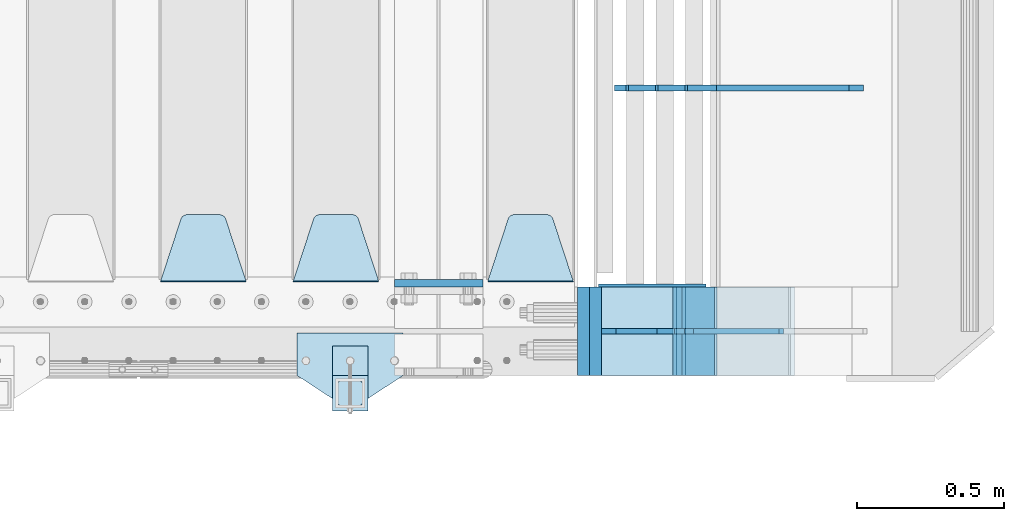
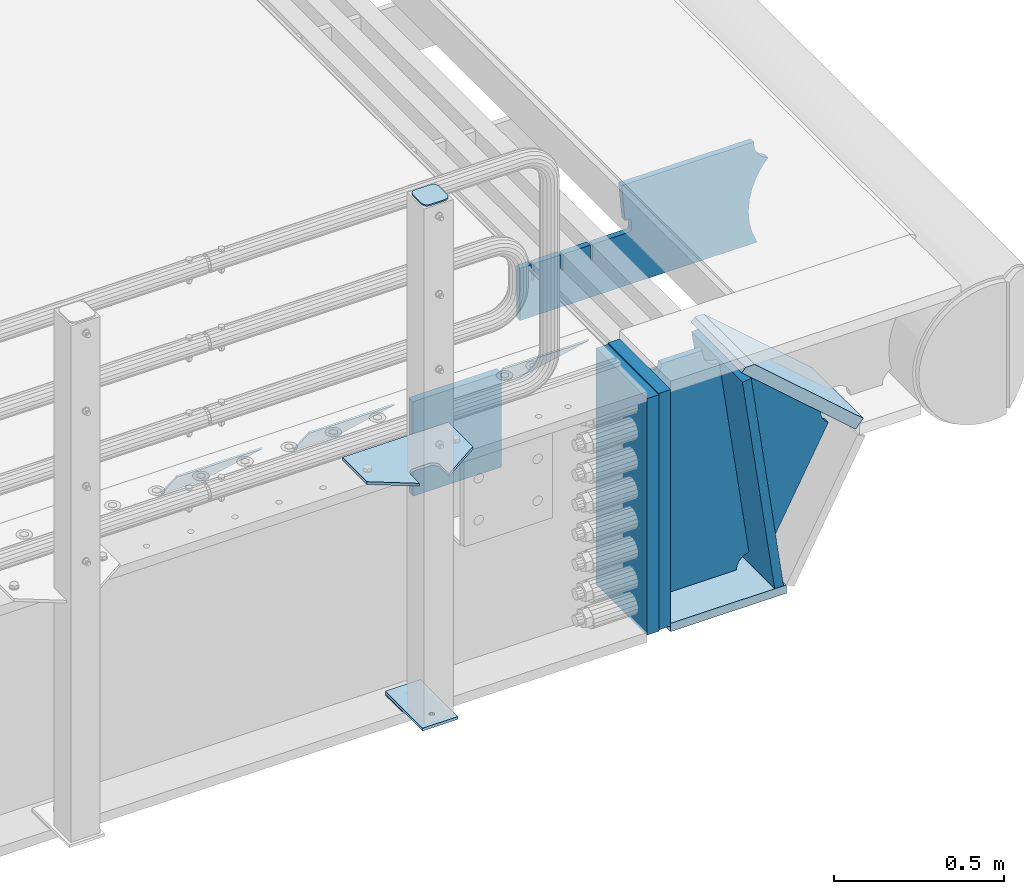
# One storey, part 242 of 270: 17 plates.
"""IFC2X3 building model written with IfcOpenShell, lengths in millimetres."""

import ifcopenshell
import ifcopenshell.guid

model = None  # the IFC model being written
_history = None  # IfcOwnerHistory: only IFC2X3 demands one
_inside = {}  # id of a spatial element -> (the spatial element, [elements in it])
_under = {}  # id of a project, library or spatial element -> (it, [spatial elements below it])
_declared = {}  # id of a project -> (the project, [libraries it declares])
_typed = {}  # id of a type object -> (the type object, [elements of that type])
_made_of = {}  # id of a material, layer set ... -> (it, [elements and type objects made of it])


def new_model(schema):
    """Start an empty IFC model of exactly this schema.

    Asked for "IFC4X3", IfcOpenShell would pick the latest addendum, in which some entities
    have other attributes; the version numbers below select the first issue.
    IFC2X3 requires an IfcOwnerHistory on every rooted entity: one is made here for all.
    """
    global model, _history
    if schema == "IFC4X3":
        model = ifcopenshell.file(schema_version=(4, 3, 0, 0))
    else:
        model = ifcopenshell.file(schema=schema)
    _inside.clear()
    _under.clear()
    _declared.clear()
    _typed.clear()
    _made_of.clear()
    _history = None
    if model.schema == "IFC2X3":
        org = make("IfcOrganization", Name="unknown")
        user = make(
            "IfcPersonAndOrganization",
            ThePerson=make("IfcPerson", FamilyName="unknown"),
            TheOrganization=org,
        )
        app = make(
            "IfcApplication",
            ApplicationDeveloper=org,
            Version="unknown",
            ApplicationFullName="unknown",
            ApplicationIdentifier="unknown",
        )
        _history = make(
            "IfcOwnerHistory",
            OwningUser=user,
            OwningApplication=app,
            ChangeAction="ADDED",
            CreationDate=0,
        )
    return model


def make(cls, **values):
    """One entity of the class cls with the attributes given. An attribute that is None is left unset."""
    return model.create_entity(
        cls, **{name: value for name, value in values.items() if value is not None}
    )


def rooted(cls, **values):
    """An entity with a GlobalId (a new one), such as an element, a storey or a relation."""
    return make(cls, GlobalId=ifcopenshell.guid.new(), OwnerHistory=_history, **values)


def si_unit(unit_type, name, prefix=None):
    """IfcSIUnit, for example si_unit("LENGTHUNIT", "METRE", prefix="MILLI")."""
    return make("IfcSIUnit", UnitType=unit_type, Prefix=prefix, Name=name)


def assignment(units):
    """IfcUnitAssignment: the units of a project."""
    return None if units is None else make("IfcUnitAssignment", Units=units)


def point(xyz):
    """IfcCartesianPoint."""
    return None if xyz is None else make("IfcCartesianPoint", Coordinates=xyz)


def direction(xyz):
    """IfcDirection."""
    return None if xyz is None else make("IfcDirection", DirectionRatios=xyz)


def frame(location, z_axis=None, x_axis=None):
    """IfcAxis2Placement3D, a coordinate frame: its origin and axes. An axis left out is left unset."""
    return make(
        "IfcAxis2Placement3D",
        Location=point(location),
        Axis=direction(z_axis),
        RefDirection=direction(x_axis),
    )


def origin_with_axes():
    """The frame at (0, 0, 0) with the z axis (0, 0, 1) and the x axis (1, 0, 0) written out."""
    return frame((0.0, 0.0, 0.0), z_axis=(0.0, 0.0, 1.0), x_axis=(1.0, 0.0, 0.0))


def place(relative_to, where):
    """IfcLocalPlacement: puts the frame where relative to a parent placement (None: the world)."""
    return make(
        "IfcLocalPlacement", PlacementRelTo=relative_to, RelativePlacement=where
    )


def context(
    kind, dimensions, precision=None, world=None, true_north=None, identifier=None
):
    """IfcGeometricRepresentationContext, for example the 3D "Model" context."""
    return make(
        "IfcGeometricRepresentationContext",
        ContextIdentifier=identifier,
        ContextType=kind,
        CoordinateSpaceDimension=dimensions,
        Precision=precision,
        WorldCoordinateSystem=world,
        TrueNorth=true_north,
    )


def subcontext(parent, identifier, kind, view, scale=None):
    """IfcGeometricRepresentationSubContext, for example "Body" below "Model"."""
    return make(
        "IfcGeometricRepresentationSubContext",
        ContextIdentifier=identifier,
        ContextType=kind,
        ParentContext=parent,
        TargetScale=scale,
        TargetView=view,
    )


def project(units=None, contexts=None):
    """IfcProject with its units and contexts."""
    return rooted(
        "IfcProject",
        Name="project",
        RepresentationContexts=contexts,
        UnitsInContext=assignment(units),
    )


def spatial(cls, under=None, at=None, **own):
    """A site, building, storey or space (cls), placed at a placement, below another one or the project."""
    s = rooted(cls, ObjectPlacement=at, **own)
    if under is not None:
        _under.setdefault(under.id(), (under, []))[1].append(s)
    return s


def faces_of(points, faces, orient=None, outer=None):
    """IfcFace entities. A face is a list of loops; a loop is a list of indices into points, from 0.

    orient and outer hold one flag for each loop. By default every Orientation is true, the
    first loop of a face is its IfcFaceOuterBound and the others are IfcFaceBound.
    """
    made = []
    for i, loops in enumerate(faces):
        bounds = []
        for j, loop in enumerate(loops):
            is_outer = j == 0 if outer is None else outer[i][j]
            bounds.append(
                make(
                    "IfcFaceOuterBound" if is_outer else "IfcFaceBound",
                    Bound=make("IfcPolyLoop", Polygon=[points[k] for k in loop]),
                    Orientation=True if orient is None else orient[i][j],
                )
            )
        made.append(make("IfcFace", Bounds=bounds))
    return made


def faceted_brep(points, faces, orient=None, outer=None, voids=None):
    """IfcFacetedBrep: a solid bounded by flat faces; with voids (closed shells), ...WithVoids."""
    shared = [point(p) for p in points]
    hull = make("IfcClosedShell", CfsFaces=faces_of(shared, faces, orient, outer))
    if voids is None:
        return make("IfcFacetedBrep", Outer=hull)
    return make(
        "IfcFacetedBrepWithVoids",
        Outer=hull,
        Voids=[
            make(cls, CfsFaces=faces_of(shared, fs, o, b)) for cls, fs, o, b in voids
        ],
    )


def shape(context_of_items, identifier, shape_type, items):
    """IfcShapeRepresentation: the items that make up one representation, for example the "Body"."""
    return make(
        "IfcShapeRepresentation",
        ContextOfItems=context_of_items,
        RepresentationIdentifier=identifier,
        RepresentationType=shape_type,
        Items=items,
    )


def material(Name=None, Category=None):
    """IfcMaterial."""
    return make("IfcMaterial", Name=Name, Category=Category)


def made_of(thing, what):
    """Note that an element or type object is made of a material, layer set ...; save() writes the relation."""
    if what is not None:
        _made_of.setdefault(what.id(), (what, []))[1].append(thing)
    return thing


def type_object(cls, material=None, **own):
    """A type object (cls), such as IfcWallType, which elements share."""
    return made_of(rooted(cls, **own), material)


def element(
    cls,
    number,
    at=None,
    inside=None,
    cuts=None,
    type_object=None,
    material=None,
    context=None,
    identifier="Body",
    shape_type=None,
    held_by="IfcProductDefinitionShape",
    body=None,
    shapes=None,
    **own,
):
    """One element of the class cls, such as IfcWall. Its Tag is "e" and its number.

    at: its placement. inside: the storey or other place that contains it. cuts: it is an
    opening in that element (IfcRelVoidsElement). A single representation is given by context,
    identifier, shape_type and body (its items); several are given by shapes. held_by: the class
    of the entity that holds the representations. save() writes the other relations.
    """
    e = rooted(cls, Tag="e%d" % number, ObjectPlacement=at, **own)
    if body is not None:
        shapes = [shape(context, identifier, shape_type, body)]
    if shapes is not None:
        e.Representation = make(held_by, Representations=shapes)
    if inside is not None:
        _inside.setdefault(inside.id(), (inside, []))[1].append(e)
    if cuts is not None:
        rooted(
            "IfcRelVoidsElement", RelatingBuildingElement=cuts, RelatedOpeningElement=e
        )
    if type_object is not None:
        _typed.setdefault(type_object.id(), (type_object, []))[1].append(e)
    return made_of(e, material)


def aggregate(whole, parts):
    """IfcRelAggregates: a whole, such as a stair, and the parts it consists of."""
    return rooted("IfcRelAggregates", RelatingObject=whole, RelatedObjects=parts)


def save(model, path):
    """Write the relations noted so far, then the file.

    IfcRelAggregates (storeys below a building ...), IfcRelContainedInSpatialStructure (elements
    in a storey), IfcRelDefinesByType, IfcRelAssociatesMaterial and IfcRelDeclares: one each for
    every whole, place, type object, material and project.
    """
    for whole, parts in _under.values():
        aggregate(whole, parts)
    for where, things in _inside.values():
        rooted(
            "IfcRelContainedInSpatialStructure",
            RelatedElements=things,
            RelatingStructure=where,
        )
    for kind, things in _typed.values():
        rooted("IfcRelDefinesByType", RelatedObjects=things, RelatingType=kind)
    for what, things in _made_of.values():
        rooted("IfcRelAssociatesMaterial", RelatedObjects=things, RelatingMaterial=what)
    for by, libraries in _declared.values():
        rooted("IfcRelDeclares", RelatingContext=by, RelatedDefinitions=libraries)
    model.write(path)


model = new_model("IFC2X3")

# Units and contexts
model_context = context("Model", 3, precision=1e-05, world=origin_with_axes())
body_context = subcontext(model_context, "Body", "Model", "MODEL_VIEW")
ifc_project = project(units=[si_unit("LENGTHUNIT", "METRE", prefix="MILLI"), si_unit("AREAUNIT", "SQUARE_METRE"), si_unit("VOLUMEUNIT", "CUBIC_METRE"), si_unit("MASSUNIT", "GRAM", prefix="KILO"), si_unit("TIMEUNIT", "SECOND"), si_unit("PLANEANGLEUNIT", "RADIAN"), si_unit("SOLIDANGLEUNIT", "STERADIAN"), si_unit("THERMODYNAMICTEMPERATUREUNIT", "DEGREE_CELSIUS"), si_unit("LUMINOUSINTENSITYUNIT", "LUMEN")], contexts=[model_context])

# Site, building, storey
site_placement = place(None, origin_with_axes())
site = spatial("IfcSite", under=ifc_project, at=site_placement, CompositionType="ELEMENT")
building_placement = place(site_placement, origin_with_axes())
building = spatial("IfcBuilding", under=site, at=building_placement, Name="Standard", CompositionType="ELEMENT")
storey_placement = place(building_placement, origin_with_axes())
storey = spatial("IfcBuildingStorey", under=building, at=storey_placement, Name="Undefined", CompositionType="ELEMENT", Elevation=0.0)

# Plates
ifc_material_1 = material(Name="STEEL/S355N")
plate_type_1 = type_object("IfcPlateType", PredefinedType="NOTDEFINED")
plate_1_placement = place(storey_placement, frame((19768.0, -23837.5, -340.000000000044), z_axis=(0.0, 0.0, 1.0), x_axis=(1.0, 0.0, 0.0)))
element("IfcPlate", 1, at=plate_1_placement, inside=storey, type_object=plate_type_1, material=ifc_material_1, context=body_context, shape_type="Brep", body=[
    faceted_brep([(0.0, -12.5, 0.0), (9.27684595808387e-10, -12.5, 340.0), (9.27684595808387e-10, 12.5, 340.0), (0.0, 12.5, 0.0), (300.0, -12.5, 340.0), (300.0, 12.5, 340.0), (300.0, -12.5, 0.0), (300.0, 12.5, 0.0)], [[[0, 1, 2, 3]], [[1, 4, 5, 2]], [[4, 6, 7, 5]], [[6, 0, 3, 7]], [[5, 7, 3, 2]], [[6, 4, 1, 0]]]),
])
ifc_material_2 = material(Name="STEEL/S355J2")
plate_type_2 = type_object("IfcPlateType", PredefinedType="NOTDEFINED")
plate_2_placement = place(storey_placement, frame((19798.0, -24005.0, 5.00000000004911), z_axis=(0.0, -1.0, 0.0), x_axis=(-1.0, 0.0, 0.0)))
element("IfcPlate", 2, at=plate_2_placement, inside=storey, type_object=plate_type_2, material=ifc_material_2, context=body_context, shape_type="Brep", body=[
    faceted_brep([(0.0, -5.0, 0.0), (2.31396552408114e-06, -5.0, 145.0), (2.31396552408114e-06, 5.0, 145.0), (0.0, 5.0, 0.0), (130.0, -5.0, 230.0), (130.0, 5.0, 230.0), (130.0, -5.0, 180.0), (130.0, 5.0, 180.0), (130.48036798992, -5.0, 175.122741949597), (130.48036798992, 5.0, 175.122741949597), (131.903011687216, -5.0, 170.432914190873), (131.903011687216, 5.0, 170.432914190873), (134.213259692435, -5.0, 166.11074417451), (134.213259692435, 5.0, 166.11074417451), (137.322330470335, -5.0, 162.322330470337), (137.322330470335, 5.0, 162.322330470337), (141.110744174512, -5.0, 159.213259692437), (141.110744174512, 5.0, 159.213259692437), (145.432914190871, -5.0, 156.903011687218), (145.432914190871, 5.0, 156.903011687218), (150.122741949595, -5.0, 155.48036798992), (150.122741949595, 5.0, 155.48036798992), (155.0, -5.0, 155.0), (155.0, 5.0, 155.0), (205.0, -5.0, 155.0), (205.0, 5.0, 155.0), (209.877258050405, -5.0, 155.48036798992), (209.877258050405, 5.0, 155.48036798992), (214.567085809129, -5.0, 156.903011687218), (214.567085809129, 5.0, 156.903011687218), (218.889255825488, -5.0, 159.213259692437), (218.889255825488, 5.0, 159.213259692437), (222.677669529665, -5.0, 162.322330470337), (222.677669529665, 5.0, 162.322330470337), (225.786740307565, -5.0, 166.11074417451), (225.786740307565, 5.0, 166.11074417451), (228.096988312784, -5.0, 170.432914190873), (228.096988312784, 5.0, 170.432914190873), (229.51963201008, -5.0, 175.122741949597), (229.51963201008, 5.0, 175.122741949597), (230.0, -5.0, 180.0), (230.0, 5.0, 180.0), (230.0, -5.0, 230.0), (230.0, 5.0, 230.0), (360.0, -5.0, 145.0), (360.0, 5.0, 145.0), (360.0, -5.0, -7.27595761418343e-12), (360.0, 5.0, -7.27595761418343e-12)], [[[0, 1, 2, 3]], [[1, 4, 5, 2]], [[4, 6, 7, 5]], [[6, 8, 9, 7]], [[8, 10, 11, 9]], [[10, 12, 13, 11]], [[12, 14, 15, 13]], [[14, 16, 17, 15]], [[16, 18, 19, 17]], [[18, 20, 21, 19]], [[20, 22, 23, 21]], [[22, 24, 25, 23]], [[24, 26, 27, 25]], [[26, 28, 29, 27]], [[28, 30, 31, 29]], [[30, 32, 33, 31]], [[32, 34, 35, 33]], [[34, 36, 37, 35]], [[36, 38, 39, 37]], [[38, 40, 41, 39]], [[40, 42, 43, 41]], [[42, 44, 45, 43]], [[44, 46, 47, 45]], [[46, 0, 3, 47]], [[5, 7, 9, 11, 13, 15, 17, 19, 21, 23, 25, 27, 29, 31, 33, 35, 37, 39, 41, 43, 45, 47, 3, 2]], [[46, 44, 42, 40, 38, 36, 34, 32, 30, 28, 26, 24, 22, 20, 18, 16, 14, 12, 10, 8, 6, 4, 1, 0]]]),
])
plate_type_3 = type_object("IfcPlateType", PredefinedType="NOTDEFINED")
plate_3_placement = place(storey_placement, frame((19677.9999999999, -24050.0000000002, -850.000000000002), z_axis=(0.0, -1.0, 0.0), x_axis=(-1.0, 0.0, 0.0)))
element("IfcPlate", 3, at=plate_3_placement, inside=storey, type_object=plate_type_3, material=ifc_material_2, context=body_context, shape_type="Brep", body=[
    faceted_brep([(53.6360389691836, -5.0, 176.363961030471), (53.6360389691836, 5.0, 176.363961030471), (59.9999999998618, 5.0, 178.999999999793), (59.9999999998618, -5.0, 178.999999999793), (66.3639610305399, 5.0, 176.363961030471), (66.3639610305399, -5.0, 176.363961030471), (68.9999999998618, 5.0, 169.999999999793), (68.9999999998618, -5.0, 169.999999999793), (66.3639610305399, 5.0, 163.636038969114), (66.3639610305399, -5.0, 163.636038969114), (59.9999999998618, 5.0, 160.999999999793), (59.9999999998618, -5.0, 160.999999999793), (53.6360389691836, 5.0, 163.636038969114), (53.6360389691836, -5.0, 163.636038969114), (50.9999999998618, 5.0, 169.999999999793), (50.9999999998618, -5.0, 169.999999999793), (120.0, -5.0, 0.0), (120.0, -5.0, 220.0), (0.0, -5.0, 220.0), (0.0, -5.0, 0.0), (0.0, 5.0, 0.0), (120.0, 5.0, 0.0), (120.0, 5.0, 220.0), (0.0, 5.0, 220.0)], [[[0, 1, 2, 3]], [[3, 2, 4, 5]], [[5, 4, 6, 7]], [[7, 6, 8, 9]], [[9, 8, 10, 11]], [[11, 10, 12, 13]], [[13, 12, 14, 15]], [[15, 14, 1, 0]], [[16, 17, 18, 19], [11, 13, 15, 0, 3, 5, 7, 9]], [[16, 19, 20, 21]], [[17, 16, 21, 22]], [[18, 17, 22, 23]], [[19, 18, 23, 20]], [[22, 21, 20, 23], [2, 1, 14, 12, 10, 8, 6, 4]]]),
])
plate_type_4 = type_object("IfcPlateType", PredefinedType="NOTDEFINED")
plate_4_placement = place(storey_placement, frame((19573.9999999999, -24166.0000000002, 1012.50000000001), z_axis=(0.0, -1.0, 0.0), x_axis=(1.0, 0.0, 0.0)))
element("IfcPlate", 4, at=plate_4_placement, inside=storey, type_object=plate_type_4, material=ifc_material_2, context=body_context, shape_type="Brep", body=[
    faceted_brep([(0.0, -2.5, 19.0), (0.0, -2.5, 69.0), (0.0, 2.5, 69.0), (0.0, 2.5, 19.0), (0.476369668544066, -2.5, 73.2278977451697), (0.476369668544066, 2.5, 73.2278977451697), (1.88159150985302, -2.5, 77.2437910432327), (1.88159150985302, 2.5, 77.2437910432327), (4.14520183310742, -2.5, 80.8463062353167), (4.14520183310742, 2.5, 80.8463062353167), (7.15369376468516, -2.5, 83.8547981668926), (7.15369376468516, 2.5, 83.8547981668926), (10.7562089567655, -2.5, 86.1184084901452), (10.7562089567655, 2.5, 86.1184084901452), (14.7721022548285, -2.5, 87.5236303314541), (14.7721022548285, 2.5, 87.5236303314541), (19.0, -2.5, 88.0), (19.0, 2.5, 88.0), (69.0, -2.5, 88.0), (69.0, 2.5, 88.0), (73.2278977451715, -2.5, 87.5236303314541), (73.2278977451715, 2.5, 87.5236303314541), (77.2437910432345, -2.5, 86.1184084901452), (77.2437910432345, 2.5, 86.1184084901452), (80.8463062353148, -2.5, 83.8547981668926), (80.8463062353148, 2.5, 83.8547981668926), (83.8547981668926, -2.5, 80.8463062353167), (83.8547981668926, 2.5, 80.8463062353167), (86.118408490147, -2.5, 77.2437910432345), (86.118408490147, 2.5, 77.2437910432345), (87.5236303314559, -2.5, 73.2278977451697), (87.5236303314559, 2.5, 73.2278977451697), (88.0, -2.5, 69.0), (88.0, 2.5, 69.0), (88.0, -2.5, 19.0), (88.0, 2.5, 19.0), (87.5236303314559, -2.5, 14.7721022548303), (87.5236303314559, 2.5, 14.7721022548303), (86.118408490147, -2.5, 10.7562089567673), (86.118408490147, 2.5, 10.7562089567673), (83.8547981668926, -2.5, 7.15369376468334), (83.8547981668926, 2.5, 7.15369376468334), (80.8463062353148, -2.5, 4.14520183310742), (80.8463062353148, 2.5, 4.14520183310742), (77.2437910432345, -2.5, 1.88159150985484), (77.2437910432345, 2.5, 1.88159150985484), (73.2278977451715, -2.5, 0.476369668545885), (73.2278977451715, 2.5, 0.476369668545885), (69.0, -2.5, 0.0), (69.0, 2.5, 0.0), (19.0, -2.5, 0.0), (19.0, 2.5, 0.0), (14.7721022548285, -2.5, 0.476369668545885), (14.7721022548285, 2.5, 0.476369668545885), (10.7562089567655, -2.5, 1.88159150985484), (10.7562089567655, 2.5, 1.88159150985484), (7.15369376468516, -2.5, 4.14520183310742), (7.15369376468516, 2.5, 4.14520183310742), (4.14520183310742, -2.5, 7.15369376468334), (4.14520183310742, 2.5, 7.15369376468334), (1.88159150985302, -2.5, 10.7562089567673), (1.88159150985302, 2.5, 10.7562089567673), (0.476369668544066, -2.5, 14.7721022548303), (0.476369668544066, 2.5, 14.7721022548303)], [[[0, 1, 2, 3]], [[1, 4, 5, 2]], [[4, 6, 7, 5]], [[6, 8, 9, 7]], [[8, 10, 11, 9]], [[10, 12, 13, 11]], [[12, 14, 15, 13]], [[14, 16, 17, 15]], [[16, 18, 19, 17]], [[18, 20, 21, 19]], [[20, 22, 23, 21]], [[22, 24, 25, 23]], [[24, 26, 27, 25]], [[26, 28, 29, 27]], [[28, 30, 31, 29]], [[30, 32, 33, 31]], [[32, 34, 35, 33]], [[34, 36, 37, 35]], [[36, 38, 39, 37]], [[38, 40, 41, 39]], [[40, 42, 43, 41]], [[42, 44, 45, 43]], [[44, 46, 47, 45]], [[46, 48, 49, 47]], [[48, 50, 51, 49]], [[50, 52, 53, 51]], [[52, 54, 55, 53]], [[54, 56, 57, 55]], [[56, 58, 59, 57]], [[58, 60, 61, 59]], [[60, 62, 63, 61]], [[62, 0, 3, 63]], [[5, 7, 9, 11, 13, 15, 17, 19, 21, 23, 25, 27, 29, 31, 33, 35, 37, 39, 41, 43, 45, 47, 49, 51, 53, 55, 57, 59, 61, 63, 3, 2]], [[62, 60, 58, 56, 54, 52, 50, 48, 46, 44, 42, 40, 38, 36, 34, 32, 30, 28, 26, 24, 22, 20, 18, 16, 14, 12, 10, 8, 6, 4, 1, 0]]]),
])
plate_type_5 = type_object("IfcPlateType", PredefinedType="NOTDEFINED")
plate_5_placement = place(storey_placement, frame((19677.9999999999, -24050.0000000002, -857.500000000002), z_axis=(0.0, -1.0, 0.0), x_axis=(-1.0, 0.0, 0.0)))
element("IfcPlate", 5, at=plate_5_placement, inside=storey, type_object=plate_type_5, material=ifc_material_2, context=body_context, shape_type="Brep", body=[
    faceted_brep([(0.0, -2.5, 0.0), (0.0, -2.5, 100.0), (0.0, 2.5, 100.0), (0.0, 2.5, 0.0), (120.0, -2.5, 100.0), (120.0, 2.5, 100.0), (120.0, -2.5, 0.0), (120.0, 2.5, 0.0)], [[[0, 1, 2, 3]], [[1, 4, 5, 2]], [[4, 6, 7, 5]], [[6, 0, 3, 7]], [[5, 7, 3, 2]], [[6, 4, 1, 0]]]),
])
plate_type_6 = type_object("IfcPlateType", PredefinedType="NOTDEFINED")
plate_6_placement = place(storey_placement, frame((20375.0, -23831.767766953, -1.76776695296758), z_axis=(0.0, 0.707106781186547, -0.707106781186548), x_axis=(-1.0, 0.0, 0.0)))
element("IfcPlate", 6, at=plate_6_placement, inside=storey, type_object=plate_type_6, material=ifc_material_1, context=body_context, shape_type="Brep", body=[
    faceted_brep([(0.0, -2.5, 0.0), (69.345504679477, -2.5, 300.171731424831), (69.345504679477, 2.5, 300.171731424831), (0.0, 2.5, 0.0), (70.9274061199576, -2.5, 304.8974424154), (70.9274061199576, 2.5, 304.8974424154), (73.3818627772307, -2.49999999999818, 309.234538108527), (73.3818627772307, 2.50000000000182, 309.234538108527), (76.6187032999551, -2.5, 313.023683126103), (76.6187032999551, 2.5, 313.023683126103), (80.5190132704993, -2.5, 316.125672595372), (80.5190132704993, 2.50000000000182, 316.125672595372), (84.9395038596849, -2.49999999999818, 318.426546230476), (84.9395038596849, 2.5, 318.426546230476), (89.7177759439219, -2.49999999999818, 319.841774983275), (89.7177759439219, 2.50000000000182, 319.841774983275), (94.678286292652, -2.5, 320.319366455078), (94.678286292652, 2.5, 320.319366455078), (195.321713707348, -2.5, 320.319366455078), (195.321713707348, 2.5, 320.319366455078), (200.282224056078, -2.49999999999818, 319.841774983275), (200.282224056078, 2.50000000000182, 319.841774983275), (205.060496140315, -2.5, 318.426546230476), (205.060496140315, 2.5, 318.426546230476), (209.480986729501, -2.5, 316.12567259537), (209.480986729501, 2.50000000000182, 316.12567259537), (213.381296700045, -2.5, 313.023683126103), (213.381296700045, 2.5, 313.023683126103), (216.618137222769, -2.49999999999818, 309.234538108525), (216.618137222769, 2.50000000000182, 309.234538108527), (219.072593880042, -2.49999999999818, 304.897442415398), (219.072593880042, 2.50000000000182, 304.897442415397), (220.654495320523, -2.5, 300.171731424831), (220.654495320523, 2.5, 300.171731424831), (290.0, -2.49999999999818, 0.0), (290.0, 2.5, 0.0)], [[[0, 1, 2, 3]], [[1, 4, 5, 2]], [[4, 6, 7, 5]], [[6, 8, 9, 7]], [[8, 10, 11, 9]], [[10, 12, 13, 11]], [[12, 14, 15, 13]], [[14, 16, 17, 15]], [[16, 18, 19, 17]], [[18, 20, 21, 19]], [[20, 22, 23, 21]], [[22, 24, 25, 23]], [[24, 26, 27, 25]], [[26, 28, 29, 27]], [[28, 30, 31, 29]], [[30, 32, 33, 31]], [[32, 34, 35, 33]], [[34, 0, 3, 35]], [[5, 7, 9, 11, 13, 15, 17, 19, 21, 23, 25, 27, 29, 31, 33, 35, 3, 2]], [[34, 32, 30, 28, 26, 24, 22, 20, 18, 16, 14, 12, 10, 8, 6, 4, 1, 0]]]),
])
plate_7_placement = place(storey_placement, frame((19715.0, -23831.767766953, -1.76776695296758), z_axis=(0.0, 0.707106781186547, -0.707106781186548), x_axis=(-1.0, 0.0, 0.0)))
element("IfcPlate", 7, at=plate_7_placement, inside=storey, type_object=plate_type_6, material=ifc_material_1, context=body_context, shape_type="Brep", body=[
    faceted_brep([(0.0, -2.5, 0.0), (69.345504679477, -2.5, 300.171731424831), (69.345504679477, 2.5, 300.171731424831), (0.0, 2.5, 0.0), (70.9274061199576, -2.5, 304.8974424154), (70.9274061199576, 2.5, 304.8974424154), (73.3818627772307, -2.49999999999818, 309.234538108527), (73.3818627772307, 2.50000000000182, 309.234538108527), (76.6187032999551, -2.5, 313.023683126103), (76.6187032999551, 2.5, 313.023683126103), (80.5190132704993, -2.5, 316.125672595372), (80.5190132704993, 2.50000000000182, 316.125672595372), (84.9395038596849, -2.49999999999818, 318.426546230476), (84.9395038596849, 2.5, 318.426546230476), (89.7177759439219, -2.49999999999818, 319.841774983275), (89.7177759439219, 2.50000000000182, 319.841774983275), (94.678286292652, -2.5, 320.319366455078), (94.678286292652, 2.5, 320.319366455078), (195.321713707348, -2.5, 320.319366455078), (195.321713707348, 2.5, 320.319366455078), (200.282224056078, -2.49999999999818, 319.841774983275), (200.282224056078, 2.50000000000182, 319.841774983275), (205.060496140315, -2.5, 318.426546230476), (205.060496140315, 2.5, 318.426546230476), (209.480986729501, -2.5, 316.12567259537), (209.480986729501, 2.50000000000182, 316.12567259537), (213.381296700045, -2.5, 313.023683126103), (213.381296700045, 2.5, 313.023683126103), (216.618137222769, -2.49999999999818, 309.234538108525), (216.618137222769, 2.50000000000182, 309.234538108527), (219.072593880042, -2.49999999999818, 304.897442415398), (219.072593880042, 2.50000000000182, 304.897442415397), (220.654495320523, -2.5, 300.171731424831), (220.654495320523, 2.5, 300.171731424831), (290.0, -2.49999999999818, 0.0), (290.0, 2.5, 0.0)], [[[0, 1, 2, 3]], [[1, 4, 5, 2]], [[4, 6, 7, 5]], [[6, 8, 9, 7]], [[8, 10, 11, 9]], [[10, 12, 13, 11]], [[12, 14, 15, 13]], [[14, 16, 17, 15]], [[16, 18, 19, 17]], [[18, 20, 21, 19]], [[20, 22, 23, 21]], [[22, 24, 25, 23]], [[24, 26, 27, 25]], [[26, 28, 29, 27]], [[28, 30, 31, 29]], [[30, 32, 33, 31]], [[32, 34, 35, 33]], [[34, 0, 3, 35]], [[5, 7, 9, 11, 13, 15, 17, 19, 21, 23, 25, 27, 29, 31, 33, 35, 3, 2]], [[34, 32, 30, 28, 26, 24, 22, 20, 18, 16, 14, 12, 10, 8, 6, 4, 1, 0]]]),
])
plate_8_placement = place(storey_placement, frame((19265.0, -23831.767766953, -1.76776695296758), z_axis=(0.0, 0.707106781186547, -0.707106781186548), x_axis=(-1.0, 0.0, 0.0)))
element("IfcPlate", 8, at=plate_8_placement, inside=storey, type_object=plate_type_6, material=ifc_material_1, context=body_context, shape_type="Brep", body=[
    faceted_brep([(0.0, -2.5, 0.0), (69.345504679477, -2.5, 300.171731424831), (69.345504679477, 2.5, 300.171731424831), (0.0, 2.5, 0.0), (70.9274061199576, -2.5, 304.8974424154), (70.9274061199576, 2.5, 304.8974424154), (73.3818627772307, -2.49999999999818, 309.234538108527), (73.3818627772307, 2.50000000000182, 309.234538108527), (76.6187032999551, -2.5, 313.023683126103), (76.6187032999551, 2.5, 313.023683126103), (80.5190132704993, -2.5, 316.125672595372), (80.5190132704993, 2.50000000000182, 316.125672595372), (84.9395038596849, -2.49999999999818, 318.426546230476), (84.9395038596849, 2.5, 318.426546230476), (89.7177759439219, -2.49999999999818, 319.841774983275), (89.7177759439219, 2.50000000000182, 319.841774983275), (94.678286292652, -2.5, 320.319366455078), (94.678286292652, 2.5, 320.319366455078), (195.321713707348, -2.5, 320.319366455078), (195.321713707348, 2.5, 320.319366455078), (200.282224056078, -2.49999999999818, 319.841774983275), (200.282224056078, 2.50000000000182, 319.841774983275), (205.060496140315, -2.5, 318.426546230476), (205.060496140315, 2.5, 318.426546230476), (209.480986729501, -2.5, 316.12567259537), (209.480986729501, 2.50000000000182, 316.12567259537), (213.381296700045, -2.5, 313.023683126103), (213.381296700045, 2.5, 313.023683126103), (216.618137222769, -2.49999999999818, 309.234538108525), (216.618137222769, 2.50000000000182, 309.234538108527), (219.072593880042, -2.49999999999818, 304.897442415398), (219.072593880042, 2.50000000000182, 304.897442415397), (220.654495320523, -2.5, 300.171731424831), (220.654495320523, 2.5, 300.171731424831), (290.0, -2.49999999999818, 0.0), (290.0, 2.5, 0.0)], [[[0, 1, 2, 3]], [[1, 4, 5, 2]], [[4, 6, 7, 5]], [[6, 8, 9, 7]], [[8, 10, 11, 9]], [[10, 12, 13, 11]], [[12, 14, 15, 13]], [[14, 16, 17, 15]], [[16, 18, 19, 17]], [[18, 20, 21, 19]], [[20, 22, 23, 21]], [[22, 24, 25, 23]], [[24, 26, 27, 25]], [[26, 28, 29, 27]], [[28, 30, 31, 29]], [[30, 32, 33, 31]], [[32, 34, 35, 33]], [[34, 0, 3, 35]], [[5, 7, 9, 11, 13, 15, 17, 19, 21, 23, 25, 27, 29, 31, 33, 35, 3, 2]], [[34, 32, 30, 28, 26, 24, 22, 20, 18, 16, 14, 12, 10, 8, 6, 4, 1, 0]]]),
])
plate_type_7 = type_object("IfcPlateType", PredefinedType="NOTDEFINED")
plate_9_placement = place(storey_placement, frame((21111.9988298898, -23850.0000000008, -367.999999998825), z_axis=(-0.752989422949573, 0.0, 0.658032619955933), x_axis=(0.0, -1.0, 0.0)))
element("IfcPlate", 9, at=plate_9_placement, inside=storey, type_object=plate_type_7, material=ifc_material_1, context=body_context, shape_type="Brep", body=[
    faceted_brep([(-8.11269273981452e-10, 19.9999999999982, 490.766265601622), (0.0, -0.303811250943909, 514.0), (300.0, -0.303811250943909, 514.0), (300.0, 19.9999999999982, 490.766265601622), (300.0, -20.0, -1.81898940354586e-12), (300.0, -20.0000000000018, 514.000000000002), (0.0, -20.0000000000018, 514.000000000002), (0.0, -20.0, 0.0), (0.0, 20.0, 0.0), (300.0, 20.0, -1.81898940354586e-12)], [[[0, 1, 2, 3]], [[4, 5, 6, 7]], [[4, 7, 8, 9]], [[9, 8, 0, 3]], [[5, 4, 9, 3, 2]], [[6, 5, 2, 1]], [[8, 7, 6, 1, 0]]]),
])
ifc_material_3 = material()
for number, where, z_axis, x_axis in (
    (10, (20449.9988298907, -23850.0, -869.999999999526), (0.0, 0.0, 1.0), (0.0, -1.0, 0.0)),
    (11, (20410.0, -23850.0, -875.0), (0.0, 0.0, 1.0), (0.0, -1.0, 0.0)),
):
    element("IfcPlate", number, at=place(storey_placement, frame(where, z_axis=z_axis, x_axis=x_axis)), inside=storey, type_object=plate_type_7, material=ifc_material_3, context=body_context, shape_type="Brep", body=[
        faceted_brep([(0.0, -20.0, 0.0), (0.0, -20.0, 850.0), (0.0, 20.0, 850.0), (0.0, 20.0, 0.0), (300.0, -20.0, 850.0), (300.0, 20.0, 850.0), (300.0, -20.0, -1.81898940354586e-12), (300.0, 20.0, -1.81898940354586e-12)], [[[0, 1, 2, 3]], [[1, 4, 5, 2]], [[4, 6, 7, 5]], [[6, 0, 3, 7]], [[5, 7, 3, 2]], [[6, 4, 1, 0]]]),
    ])
plate_type_8 = type_object("IfcPlateType", PredefinedType="NOTDEFINED")
plate_10_placement = place(storey_placement, frame((20708.9988298891, -24000.0, -30.0000000027761), z_axis=(0.0, 0.0, -1.0), x_axis=(-1.0, 0.0, 0.0)))
element("IfcPlate", 12, at=plate_10_placement, inside=storey, type_object=plate_type_8, material=ifc_material_1, context=body_context, shape_type="Brep", body=[
    faceted_brep([(-9.00602409638668, -10.0, 65.0), (-108.137843376921, -10.0, 780.473130459514), (-108.137843376921, 10.0, 780.473130459514), (-9.00602409638668, 10.0, 65.0), (-94.4157884488377, -10.0, 784.433672138112), (-94.4157884488377, 10.0, 784.433672138112), (-82.3732461236723, -10.0, 792.112074067144), (-82.3732461236723, 10.0, 792.112074067144), (-72.9927947992364, -10.0, 802.881837982249), (-72.9927947992364, 10.0, 802.881837982249), (-67.0398068183713, -10.0, 815.864234368775), (-67.0398068183713, 10.0, 815.864234368775), (-65.0, -10.0, 830.0), (-65.0, 10.0, 830.0), (189.0, -10.0, 830.0), (189.0, 10.0, 830.0), (191.447174185243, -10.0, 814.549150281253), (191.447174185243, 10.0, 814.549150281253), (198.549150281251, -10.0, 800.610737385376), (198.549150281251, 10.0, 800.610737385376), (209.610737385377, -10.0, 789.549150281253), (209.610737385377, 10.0, 789.549150281253), (223.549150281251, -10.0, 782.447174185242), (223.549150281251, 10.0, 782.447174185242), (239.0, -10.0, 780.0), (239.0, 10.0, 780.0), (239.0, -10.0, 50.0), (239.0, 10.0, 50.0), (223.549150281251, -10.0, 47.5528258147577), (223.549150281251, 10.0, 47.5528258147577), (209.610737385377, -10.0, 40.4508497187474), (209.610737385377, 10.0, 40.4508497187474), (198.549150281251, -10.0, 29.3892626146237), (198.549150281251, 10.0, 29.3892626146237), (191.447174185243, -10.0, 15.4508497187474), (191.447174185243, 10.0, 15.4508497187474), (189.0, -10.0, 0.0), (189.0, 10.0, 0.0), (50.4776502774184, -10.0, 0.0), (50.4776502774184, 10.0, 0.0), (47.3830020671812, -10.0, 22.3352870825933), (47.3830020671812, 10.0, 22.3352870825933), (42.8384615202776, -10.0, 37.3040735979326), (42.8384615202776, 10.0, 37.3040735979326), (33.8907372011709, -10.0, 50.1358952937587), (33.8907372011709, 10.0, 50.1358952937587), (21.4156947086703, -10.0, 59.5746840579253), (21.4156947086703, 10.0, 59.5746840579253), (6.63447812067898, -10.0, 64.6965054822873), (6.63447812067898, 10.0, 64.6965054822873)], [[[0, 1, 2, 3]], [[1, 4, 5, 2]], [[4, 6, 7, 5]], [[6, 8, 9, 7]], [[8, 10, 11, 9]], [[10, 12, 13, 11]], [[12, 14, 15, 13]], [[14, 16, 17, 15]], [[16, 18, 19, 17]], [[18, 20, 21, 19]], [[20, 22, 23, 21]], [[22, 24, 25, 23]], [[24, 26, 27, 25]], [[26, 28, 29, 27]], [[28, 30, 31, 29]], [[30, 32, 33, 31]], [[32, 34, 35, 33]], [[34, 36, 37, 35]], [[36, 38, 39, 37]], [[38, 40, 41, 39]], [[40, 42, 43, 41]], [[42, 44, 45, 43]], [[44, 46, 47, 45]], [[46, 48, 49, 47]], [[48, 0, 3, 49]], [[5, 7, 9, 11, 13, 15, 17, 19, 21, 23, 25, 27, 29, 31, 33, 35, 37, 39, 41, 43, 45, 47, 49, 3, 2]], [[48, 46, 44, 42, 40, 38, 36, 34, 32, 30, 28, 26, 24, 22, 20, 18, 16, 14, 12, 10, 8, 6, 4, 1, 0]]]),
])
plate_type_9 = type_object("IfcPlateType", PredefinedType="NOTDEFINED")
plate_11_placement = place(storey_placement, frame((21111.0025685034, -23999.999999999, -393.99668820393), z_axis=(-0.658066357015091, 0.0, -0.752959939017267), x_axis=(-0.752959939017266, 0.0, 0.658066357015093)))
element("IfcPlate", 13, at=plate_11_placement, inside=storey, type_object=plate_type_9, material=ifc_material_1, context=body_context, shape_type="Brep", body=[
    faceted_brep([(-11.3595226159596, -10.0, 48.6925173505915), (-112.015767301031, -10.0, 480.154833723633), (-112.015767301031, 10.0, 480.154833723633), (-11.3595226159596, 10.0, 48.6925173505915), (-104.567323293641, -10.0, 482.519601382543), (-104.567323293641, 10.0, 482.519601382543), (-97.5783311599989, -10.0, 486.016090073756), (-97.5783311599989, 10.0, 486.016090073756), (-91.2195220373833, -10.0, 490.558885551656), (-91.2195220373833, 10.0, 490.558885551656), (-85.6462325884258, -10.0, 496.037013784004), (-85.6462325884258, 10.0, 496.037013784004), (447.024482710494, -10.0, 32.8103372896385), (447.024482710494, 10.0, 32.8103372896385), (441.786973010396, -10.0, 25.570962393731), (441.786973010396, 10.0, 25.570962393731), (437.921644570126, -10.0, 17.5149526624118), (437.921644570126, 10.0, 17.5149526624118), (435.551940606494, -10.0, 8.89958500531975), (435.551940606494, 10.0, 8.89958500531975), (434.753540039061, -10.0, -5.16592990607023e-10), (434.753540039061, 10.0, -5.16592990607023e-10), (50.0, -10.0, 0.0), (50.0, 10.0, 0.0), (47.7668538974231, -10.0, 14.7759151575174), (47.7668538974231, 10.0, 14.7759151575174), (41.2668932502802, -10.0, 28.2319592212443), (41.2668932502802, 10.0, 28.2319592212443), (31.0807325300157, -10.0, 39.1661596968297), (31.0807325300157, 10.0, 39.1661596968297), (18.1182591411489, -10.0, 46.6018098971963), (18.1182591411489, 10.0, 46.6018098971963), (3.53735696080548, -10.0, 49.874714091733), (3.53735696080548, 10.0, 49.874714091733)], [[[0, 1, 2, 3]], [[1, 4, 5, 2]], [[4, 6, 7, 5]], [[6, 8, 9, 7]], [[8, 10, 11, 9]], [[10, 12, 13, 11]], [[12, 14, 15, 13]], [[14, 16, 17, 15]], [[16, 18, 19, 17]], [[18, 20, 21, 19]], [[20, 22, 23, 21]], [[22, 24, 25, 23]], [[24, 26, 27, 25]], [[26, 28, 29, 27]], [[28, 30, 31, 29]], [[30, 32, 33, 31]], [[32, 0, 3, 33]], [[5, 7, 9, 11, 13, 15, 17, 19, 21, 23, 25, 27, 29, 31, 33, 3, 2]], [[32, 30, 28, 26, 24, 22, 20, 18, 16, 14, 12, 10, 8, 6, 4, 1, 0]]]),
])
plate_type_10 = type_object("IfcPlateType", PredefinedType="NOTDEFINED")
plate_12_placement = place(storey_placement, frame((20862.9988298891, -23850.0, -875.000000002776), z_axis=(0.0, -1.0, 0.0), x_axis=(-1.0, 0.0, 0.0)))
element("IfcPlate", 14, at=plate_12_placement, inside=storey, type_object=plate_type_10, material=ifc_material_1, context=body_context, shape_type="Brep", body=[
    faceted_brep([(0.0, -15.0, 0.0), (0.0, -15.0, 300.0), (0.0, 15.0, 300.0), (0.0, 15.0, 0.0), (393.0, -15.0, 300.0), (393.0, 15.0, 300.0), (393.0, -15.0, 0.0), (393.0, 15.0, 0.0)], [[[0, 1, 2, 3]], [[1, 4, 5, 2]], [[4, 6, 7, 5]], [[6, 0, 3, 7]], [[5, 7, 3, 2]], [[6, 4, 1, 0]]]),
])
plate_13_placement = place(storey_placement, frame((20839.1480677228, -23849.999999999, -862.083788726918), z_axis=(-0.139173011053008, 0.0, 0.990268081377179), x_axis=(0.0, -1.0, 0.0)))
element("IfcPlate", 15, at=plate_13_placement, inside=storey, type_object=plate_type_10, material=ifc_material_1, context=body_context, shape_type="Brep", body=[
    faceted_brep([(1.00408215075731e-09, 14.9994702460499, -0.00376939767329532), (300.0, 15.0, 0.0), (300.0, -15.0000000000036, 4.21237841386937), (0.0, -15.0000000000036, 4.21237841386937), (0.0, -15.0, 792.0), (300.0, -15.0, 792.0), (300.0, 14.9999999999964, 792.0), (0.0, 14.9999999999964, 792.0)], [[[0, 1, 2, 3]], [[4, 5, 6, 7]], [[4, 7, 0, 3]], [[5, 4, 3, 2]], [[6, 5, 2, 1]], [[7, 6, 1, 0]]]),
])
plate_type_11 = type_object("IfcPlateType", PredefinedType="NOTDEFINED")
plate_14_placement = place(storey_placement, frame((21355.9182339676, -23175.0007171631, -374.002067436517), z_axis=(0.0, 0.0, 1.0), x_axis=(-1.0, 0.0, 0.0)))
element("IfcPlate", 16, at=plate_14_placement, inside=storey, type_object=plate_type_11, material=ifc_material_1, context=body_context, shape_type="Brep", body=[
    faceted_brep([(801.919404066546, -10.0, 188.0), (801.919404066546, 10.0, 188.0), (801.919404066546, 10.0, 132.002067436952), (801.919404066546, -10.0, 132.002067436952), (793.919404066546, 10.0, 132.002067436952), (793.919404066546, -10.0, 132.002067436952), (793.919404066546, 10.0, 180.002067436952), (793.919404066546, -10.0, 180.002067436952), (793.527856196906, 10.0, 182.474203391951), (793.527856196906, -10.0, 182.474203391951), (792.391540021545, 10.0, 184.704349455291), (792.391540021545, -10.0, 184.704349455291), (790.621686084887, 10.0, 186.474203391951), (790.621686084887, -10.0, 186.474203391951), (788.391540021545, 10.0, 187.610519567313), (788.391540021545, -10.0, 187.610519567313), (785.919404066546, -10.0, 188.002067436952), (785.919404066546, 10.0, 188.0), (841.0, -10.0, 188.0), (841.0, -10.0, 0.0), (841.0, 10.0, 0.0), (841.0, 10.0, 188.0), (33.3619566735979, -10.0, 0.0), (33.3619566735979, 10.0, 0.0), (36.2350612208174, -10.0, 4.68848050267013), (36.2350612208174, 10.0, 4.68848050267013), (51.4877592159428, -10.0, 41.5117508652784), (51.4877592159428, 10.0, 41.5117508652784), (60.792242588137, -10.0, 80.2677133162964), (60.792242588137, 10.0, 80.2677133162964), (63.9194040769726, -10.0, 120.002067436515), (63.9194040769726, 10.0, 120.002067436515), (60.792242588137, -10.0, 159.736421556734), (60.792242588137, 10.0, 159.736421556734), (51.4877592159428, -10.0, 198.492384007752), (51.4877592159428, 10.0, 198.492384007752), (36.2350612208174, -10.0, 235.31565437036), (36.2350612208174, 10.0, 235.31565437036), (15.4097206482074, -10.0, 269.299521518803), (15.4097206482074, 10.0, 269.299521518803), (-3.35474438098754, -10.0, 291.269887256574), (-3.35474438098754, 10.0, 291.269887256574), (-2.36881039375294, -10.0, 291.426043859339), (-2.36881039375294, 10.0, 291.426043859339), (17.1449676604716, -10.0, 301.368810393754), (17.1449676604716, 10.0, 301.368810393754), (32.6311896062471, -10.0, 316.855032339527), (32.6311896062471, 10.0, 316.855032339527), (42.573956140659, -10.0, 336.368810393754), (42.573956140659, 10.0, 336.368810393754), (46.0, -10.0, 358.0), (46.0, 10.0, 358.0), (45.0495205499174, -10.0, 364.001091067617), (45.0495205499174, 10.0, 364.001091067617), (495.040008544922, -10.0, 364.010009765625), (495.040008544922, 10.0, 364.010009765625), (483.600036621094, -10.0, 233.759994506836), (483.600036621094, 10.0, 233.759994506836), (472.0, -10.0, 233.759994506836), (472.0, 10.0, 233.759994506836), (468.909830056251, -10.0, 233.270559669787), (468.909830056251, 10.0, 233.270559669787), (466.122147477075, -10.0, 231.850164450585), (466.122147477075, 10.0, 231.850164450585), (463.909830056251, -10.0, 229.637847029761), (463.909830056251, 10.0, 229.637847029761), (462.489434837047, -10.0, 226.850164450585), (462.489434837047, 10.0, 226.850164450585), (462.0, -10.0, 223.759994506836), (462.0, 10.0, 223.759994506836), (462.0, -10.0, 198.0), (462.0, 10.0, 198.0), (462.489434837047, -10.0, 194.909830056251), (462.489434837047, 10.0, 194.909830056251), (463.909830056251, -10.0, 192.122147477075), (463.909830056251, 10.0, 192.122147477075), (466.122147477075, -10.0, 189.909830056251), (466.122147477075, 10.0, 189.909830056251), (468.909830056251, -10.0, 188.489434837048), (468.909830056251, 10.0, 188.489434837048), (472.0, -10.0, 188.0), (472.0, 10.0, 188.0), (585.919404066546, -10.0, 188.002067436952), (585.919404066546, 10.0, 188.0), (588.391540021545, -10.0, 187.610519567313), (588.391540021545, 10.0, 187.610519567313), (590.621686084887, -10.0, 186.474203391951), (590.621686084887, 10.0, 186.474203391951), (592.391540021545, -10.0, 184.704349455291), (592.391540021545, 10.0, 184.704349455291), (593.527856196906, -10.0, 182.474203391951), (593.527856196906, 10.0, 182.474203391951), (593.919404066546, -10.0, 180.002067436952), (593.919404066546, 10.0, 180.002067436952), (593.919404066546, -10.0000000000036, 132.002067436952), (593.919404066546, 10.0, 132.002067436952), (601.919404066546, -10.0000000000036, 132.002067436952), (601.919404066546, 10.0, 132.002067436952), (601.919404066546, -10.0, 188.0), (601.919404066546, 10.0, 188.0), (685.919404066546, -10.0, 188.002067436952), (685.919404066546, 10.0, 188.0), (688.391540021545, -10.0, 187.610519567313), (688.391540021545, 10.0, 187.610519567313), (690.621686084887, -10.0, 186.474203391951), (690.621686084887, 10.0, 186.474203391951), (692.391540021545, -10.0, 184.704349455291), (692.391540021545, 10.0, 184.704349455291), (693.527856196906, -10.0, 182.474203391951), (693.527856196906, 10.0, 182.474203391951), (693.919404066546, -10.0, 180.002067436952), (693.919404066546, 10.0, 180.002067436952), (693.919404066546, -10.0, 132.002067436952), (693.919404066546, 10.0, 132.002067436952), (701.919404066546, -10.0, 132.002067436952), (701.919404066546, 10.0, 132.002067436952), (701.919404066546, -10.0, 188.0), (701.919404066546, 10.0, 188.0)], [[[0, 1, 2, 3]], [[3, 2, 4, 5]], [[5, 4, 6, 7]], [[7, 6, 8, 9]], [[9, 8, 10, 11]], [[11, 10, 12, 13]], [[13, 12, 14, 15]], [[16, 15, 14, 17]], [[18, 19, 20, 21]], [[20, 19, 22, 23]], [[22, 24, 25, 23]], [[26, 27, 25, 24]], [[28, 29, 27, 26]], [[30, 31, 29, 28]], [[32, 33, 31, 30]], [[34, 35, 33, 32]], [[36, 37, 35, 34]], [[38, 39, 37, 36]], [[39, 38, 40, 41]], [[40, 42, 43, 41]], [[44, 45, 43, 42]], [[46, 47, 45, 44]], [[48, 49, 47, 46]], [[50, 51, 49, 48]], [[52, 53, 51, 50]], [[54, 55, 53, 52]], [[54, 56, 57, 55]], [[56, 58, 59, 57]], [[58, 60, 61, 59]], [[60, 62, 63, 61]], [[62, 64, 65, 63]], [[64, 66, 67, 65]], [[66, 68, 69, 67]], [[68, 70, 71, 69]], [[70, 72, 73, 71]], [[72, 74, 75, 73]], [[74, 76, 77, 75]], [[76, 78, 79, 77]], [[78, 80, 81, 79]], [[81, 80, 82, 83]], [[82, 84, 85, 83]], [[86, 87, 85, 84]], [[88, 89, 87, 86]], [[90, 91, 89, 88]], [[92, 93, 91, 90]], [[94, 95, 93, 92]], [[96, 97, 95, 94]], [[98, 99, 97, 96]], [[99, 98, 100, 101]], [[100, 102, 103, 101]], [[104, 105, 103, 102]], [[106, 107, 105, 104]], [[108, 109, 107, 106]], [[110, 111, 109, 108]], [[112, 113, 111, 110]], [[114, 115, 113, 112]], [[116, 117, 115, 114]], [[117, 116, 16, 17]], [[12, 10, 8, 6, 4, 2, 1, 21, 20, 23, 25, 27, 29, 31, 33, 35, 37, 39, 41, 43, 45, 47, 49, 51, 53, 55, 57, 59, 61, 63, 65, 67, 69, 71, 73, 75, 77, 79, 81, 83, 85, 87, 89, 91, 93, 95, 97, 99, 101, 103, 105, 107, 109, 111, 113, 115, 117, 17, 14]], [[18, 21, 1, 0]], [[116, 114, 112, 110, 108, 106, 104, 102, 100, 98, 96, 94, 92, 90, 88, 86, 84, 82, 80, 78, 76, 74, 72, 70, 68, 66, 64, 62, 60, 58, 56, 54, 52, 50, 48, 46, 44, 42, 40, 38, 36, 34, 32, 30, 28, 26, 24, 22, 19, 18, 0, 3, 5, 7, 9, 11, 13, 15, 16]]]),
])
plate_type_12 = type_object("IfcPlateType", PredefinedType="NOTDEFINED")
plate_15_placement = place(storey_placement, frame((20824.998829901, -23845.0, -249.999999999564), z_axis=(-1.0, 0.0, 0.0), x_axis=(0.0, 0.0, 1.0)))
element("IfcPlate", 17, at=plate_15_placement, inside=storey, type_object=plate_type_12, material=ifc_material_1, context=body_context, shape_type="Brep", body=[
    faceted_brep([(0.0, -5.0, 0.0), (0.0, -5.0, 365.0), (0.0, 5.0, 365.0), (0.0, 5.0, 0.0), (80.0, -5.0, 365.0), (80.0, 5.0, 365.0), (80.0, -5.0, 0.0), (80.0, 5.0, 0.0)], [[[0, 1, 2, 3]], [[1, 4, 5, 2]], [[4, 6, 7, 5]], [[6, 0, 3, 7]], [[5, 7, 3, 2]], [[6, 4, 1, 0]]]),
])

save(model, "model.ifc")
